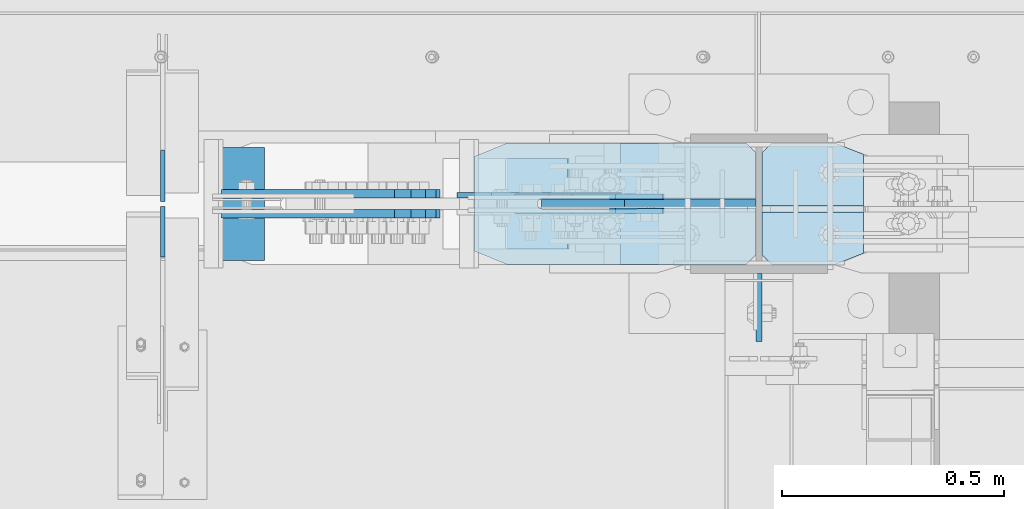
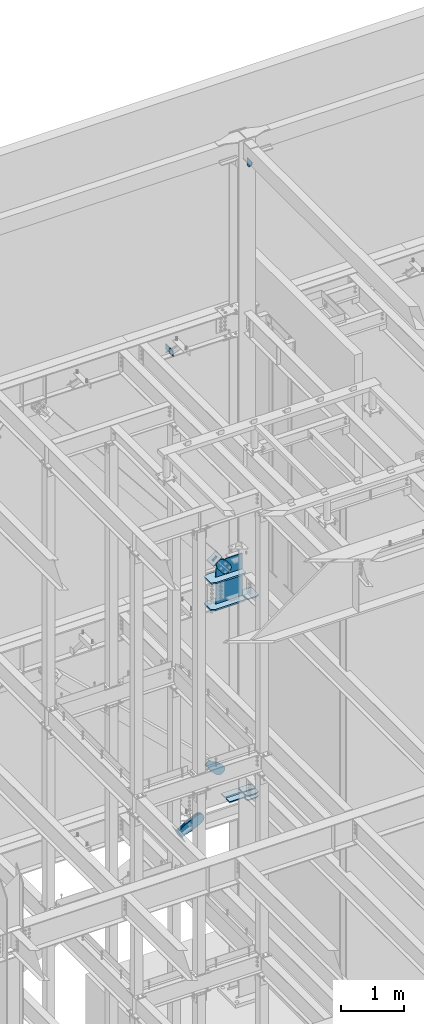
# One storey, part 1104 of 1179: 19 plates, 9 elements without a shape of their own.
"""IFC2X3 building model written with IfcOpenShell, lengths in millimetres."""

from ifc_helpers import new_model, si_unit, frame, origin_with_axes, place, context, subcontext, project, spatial, faceted_brep, material, type_object, element, aggregate, save


model = new_model("IFC2X3")

# Units and contexts
model_context = context("Model", 3, precision=1e-05, world=origin_with_axes())
body_context = subcontext(model_context, "Body", "Model", "MODEL_VIEW")
ifc_project = project(units=[si_unit("LENGTHUNIT", "METRE", prefix="MILLI"), si_unit("AREAUNIT", "SQUARE_METRE"), si_unit("VOLUMEUNIT", "CUBIC_METRE"), si_unit("MASSUNIT", "GRAM", prefix="KILO"), si_unit("TIMEUNIT", "SECOND"), si_unit("PLANEANGLEUNIT", "RADIAN"), si_unit("SOLIDANGLEUNIT", "STERADIAN"), si_unit("THERMODYNAMICTEMPERATUREUNIT", "DEGREE_CELSIUS"), si_unit("LUMINOUSINTENSITYUNIT", "LUMEN")], contexts=[model_context])

# Site, building, storey
site_placement = place(None, origin_with_axes())
site = spatial("IfcSite", under=ifc_project, at=site_placement, CompositionType="ELEMENT")
building_placement = place(site_placement, origin_with_axes())
building = spatial("IfcBuilding", under=site, at=building_placement, Name="Undefined", CompositionType="ELEMENT")
storey_placement = place(building_placement, origin_with_axes())
storey = spatial("IfcBuildingStorey", under=building, at=storey_placement, Name="Undefined", CompositionType="ELEMENT", Elevation=0.0)

# Assembly, plate
assembly_1_placement = place(storey_placement, origin_with_axes())
assembly_1 = element("IfcElementAssembly", 1, at=assembly_1_placement, inside=storey, Name="Plate", AssemblyPlace="NOTDEFINED", PredefinedType="RIGID_FRAME")
ifc_material_1 = material(Name="STEEL/A36")
plate_type_1 = type_object("IfcPlateType", PredefinedType="NOTDEFINED")
plate_1_placement = place(assembly_1_placement, frame((15871.0411167617, 41300.4, 8315.96638331913), z_axis=(0.782937860640373, 0.0, 0.622099916714249), x_axis=(0.0, -1.0, 0.0)))
plate_1 = element("IfcPlate", 2, at=plate_1_placement, type_object=plate_type_1, material=ifc_material_1, Name="Plate", context=body_context, shape_type="Brep", body=[
    faceted_brep([(0.0, -3.17500000000109, 0.0), (0.0, -3.17500000000291, 203.200000000368), (0.0, 3.17499999998836, 203.200000000361), (0.0, 3.17500000000109, 7.27595761418343e-12), (203.199999999997, -3.17500000000291, 203.200000000368), (203.199999999997, 3.17499999998836, 203.200000000361), (203.199999999997, -3.17499999999927, 3.63797880709171e-12), (203.199999999997, 3.17499999999382, -3.63797880709171e-12)], [[[0, 1, 2, 3]], [[1, 4, 5, 2]], [[4, 6, 7, 5]], [[6, 0, 3, 7]], [[5, 7, 3, 2]], [[6, 4, 1, 0]]]),
])
aggregate(assembly_1, [plate_1])

# Assembly, plates
assembly_2_placement = place(storey_placement, origin_with_axes())
assembly_2 = element("IfcElementAssembly", 3, at=assembly_2_placement, inside=storey, Name="COLUMN", AssemblyPlace="NOTDEFINED", PredefinedType="RIGID_FRAME")
ifc_material_2 = material(Name="STEEL/A572-GR.50")
plate_type_2 = type_object("IfcPlateType", PredefinedType="NOTDEFINED")
plate_2_placement = place(assembly_2_placement, frame((15817.5535981227, 41335.1078456819, 7478.71299953461), z_axis=(0.0, -1.0, 0.0), x_axis=(1.0, 0.0, 0.0)))
plate_2 = element("IfcPlate", 4, at=plate_2_placement, type_object=plate_type_2, material=ifc_material_2, Name="PLATE", context=body_context, shape_type="Brep", body=[
    faceted_brep([(0.0, -14.2875000000004, 30.1625003814697), (0.0, -14.2875000000004, 242.453264224023), (0.0, 14.2875000000004, 242.453264224023), (0.0, 14.2875000000004, 30.1625003814697), (74.6125030517578, -14.2875000000004, 272.615764605493), (74.6125030517578, 14.2875000000004, 272.615764605493), (613.071401470328, -14.2875000000004, 272.615764605493), (613.071401470328, 14.2875000000004, 272.615764605493), (635.296401851798, -14.2875000000004, 250.390764224023), (635.296401851798, 14.2875000000004, 250.390764224023), (635.296401851798, -14.2875000000004, 147.202764605485), (635.296401851798, 14.2875000000004, 147.202764605485), (153.997318827118, -14.2875000000004, 147.628018508702), (153.997318827118, 14.2875000000004, 147.628018508702), (149.741734881249, -14.2875000000004, 146.784949914079), (149.741734881249, 14.2875000000004, 146.784949914079), (146.133248221176, -14.2875000000004, 144.376717491818), (146.133248221176, 14.2875000000004, 144.376717491818), (143.721828446049, -14.2875000000004, 140.770360043687), (143.721828446049, 14.2875000000004, 140.770360043687), (142.875000142223, -14.2875000000004, 136.525345872607), (142.875000142223, 14.2875000000004, 136.525345872607), (143.720888851711, -14.2875000000004, 132.272776157457), (143.720888851711, 14.2875000000004, 132.272776157457), (146.129776092153, -14.2875000000004, 128.667621631801), (146.129776092153, 14.2875000000004, 128.667621631801), (149.734930617809, -14.2875000000004, 126.258734391362), (149.734930617809, 14.2875000000004, 126.258734391362), (153.987500332958, -14.2875000000004, 125.412845681873), (153.987500332958, 14.2875000000004, 125.412845681873), (635.296401994021, -14.2875000000004, 125.412845681873), (635.296401994021, 14.2875000000004, 125.412845681873), (635.296401877002, -14.2875000000004, 22.2250003814697), (635.296401877002, 14.2875000000004, 22.2250003814697), (613.071401470328, -14.2875000000004, 0.0), (613.071401470328, 14.2875000000004, 0.0), (74.6125030517578, -14.2875000000004, 0.0), (74.6125030517578, 14.2875000000004, 0.0)], [[[0, 1, 2, 3]], [[1, 4, 5, 2]], [[4, 6, 7, 5]], [[6, 8, 9, 7]], [[8, 10, 11, 9]], [[10, 12, 13, 11]], [[12, 14, 15, 13]], [[14, 16, 17, 15]], [[16, 18, 19, 17]], [[18, 20, 21, 19]], [[20, 22, 23, 21]], [[22, 24, 25, 23]], [[24, 26, 27, 25]], [[26, 28, 29, 27]], [[28, 30, 31, 29]], [[30, 32, 33, 31]], [[32, 34, 35, 33]], [[34, 36, 37, 35]], [[36, 0, 3, 37]], [[5, 7, 9, 11, 13, 15, 17, 19, 21, 23, 25, 27, 29, 31, 33, 35, 37, 3, 2]], [[36, 34, 32, 30, 28, 26, 24, 22, 20, 18, 16, 14, 12, 10, 8, 6, 4, 1, 0]]]),
])
plate_3_placement = place(assembly_2_placement, frame((15817.5535981227, 41335.1078456819, 7999.4125), z_axis=(0.0, -1.0, 0.0), x_axis=(1.0, 0.0, 0.0)))
plate_3 = element("IfcPlate", 5, at=plate_3_placement, type_object=plate_type_2, material=ifc_material_2, Name="PLATE", context=body_context, shape_type="Brep", body=[
    faceted_brep([(0.0, -14.2875000000004, 30.1625003814697), (0.0, -14.2875000000004, 242.453264224023), (0.0, 14.2875000000004, 242.453264224023), (0.0, 14.2875000000004, 30.1625003814697), (74.6125030517578, -14.2875000000004, 272.615764605493), (74.6125030517578, 14.2875000000004, 272.615764605493), (613.071401470328, -14.2875000000004, 272.615764605493), (613.071401470328, 14.2875000000004, 272.615764605493), (635.296401851798, -14.2875000000004, 250.390764224023), (635.296401851798, 14.2875000000004, 250.390764224023), (635.296401851798, -14.2875000000004, 147.202764605485), (635.296401851798, 14.2875000000004, 147.202764605485), (153.997318827118, -14.2875000000004, 147.628018508702), (153.997318827118, 14.2875000000004, 147.628018508702), (149.741734881249, -14.2875000000004, 146.784949914079), (149.741734881249, 14.2875000000004, 146.784949914079), (146.133248221176, -14.2875000000004, 144.376717491818), (146.133248221176, 14.2875000000004, 144.376717491818), (143.721828446049, -14.2875000000004, 140.770360043687), (143.721828446049, 14.2875000000004, 140.770360043687), (142.875000142223, -14.2875000000004, 136.525345872607), (142.875000142223, 14.2875000000004, 136.525345872607), (143.720888851711, -14.2875000000004, 132.272776157457), (143.720888851711, 14.2875000000004, 132.272776157457), (146.129776092153, -14.2875000000004, 128.667621631801), (146.129776092153, 14.2875000000004, 128.667621631801), (149.734930617809, -14.2875000000004, 126.258734391362), (149.734930617809, 14.2875000000004, 126.258734391362), (153.987500332958, -14.2875000000004, 125.412845681873), (153.987500332958, 14.2875000000004, 125.412845681873), (635.296401994021, -14.2875000000004, 125.412845681873), (635.296401994021, 14.2875000000004, 125.412845681873), (635.296401877002, -14.2875000000004, 22.2250003814697), (635.296401877002, 14.2875000000004, 22.2250003814697), (613.071401470328, -14.2875000000004, 0.0), (613.071401470328, 14.2875000000004, 0.0), (74.6125030517578, -14.2875000000004, 0.0), (74.6125030517578, 14.2875000000004, 0.0)], [[[0, 1, 2, 3]], [[1, 4, 5, 2]], [[4, 6, 7, 5]], [[6, 8, 9, 7]], [[8, 10, 11, 9]], [[10, 12, 13, 11]], [[12, 14, 15, 13]], [[14, 16, 17, 15]], [[16, 18, 19, 17]], [[18, 20, 21, 19]], [[20, 22, 23, 21]], [[22, 24, 25, 23]], [[24, 26, 27, 25]], [[26, 28, 29, 27]], [[28, 30, 31, 29]], [[30, 32, 33, 31]], [[32, 34, 35, 33]], [[34, 36, 37, 35]], [[36, 0, 3, 37]], [[5, 7, 9, 11, 13, 15, 17, 19, 21, 23, 25, 27, 29, 31, 33, 35, 37, 3, 2]], [[36, 34, 32, 30, 28, 26, 24, 22, 20, 18, 16, 14, 12, 10, 8, 6, 4, 1, 0]]]),
])
plate_type_3 = type_object("IfcPlateType", PredefinedType="NOTDEFINED")
plate_4_placement = place(assembly_2_placement, frame((16694.15, 41335.325, 3644.9), z_axis=(0.0, -1.0, 0.0), x_axis=(-1.0, 0.0, 0.0)))
plate_4 = element("IfcPlate", 6, at=plate_4_placement, type_object=plate_type_3, material=ifc_material_2, Name="PLATE", context=body_context, shape_type="Brep", body=[
    faceted_brep([(0.0, -9.52499999999964, 25.3999996185303), (0.0, -9.52500000000009, 140.493749921945), (0.0, 9.52500000000009, 140.493749921945), (0.0, 9.52499999999964, 25.3999996185303), (228.600000000002, -9.52500000000009, 140.493749921945), (228.600000000002, 9.52500000000009, 140.493749921945), (228.599999999999, -9.52499999999964, 22.2250003814697), (228.599999999999, 9.52499999999964, 22.2250003814697), (206.374999618529, -9.52499999999964, 0.0), (206.374999618529, 9.52499999999964, 0.0), (63.5, -9.52500000000009, 0.0), (63.5, 9.52500000000009, 0.0)], [[[0, 1, 2, 3]], [[1, 4, 5, 2]], [[4, 6, 7, 5]], [[6, 8, 9, 7]], [[8, 10, 11, 9]], [[10, 0, 3, 11]], [[5, 7, 9, 11, 3, 2]], [[10, 8, 6, 4, 1, 0]]]),
])
plate_type_4 = type_object("IfcPlateType", PredefinedType="NOTDEFINED")
plate_5_placement = place(assembly_2_placement, frame((16694.15, 41062.275, 3644.9), z_axis=(0.0, 1.0, 0.0), x_axis=(-1.0, 0.0, 0.0)))
plate_5 = element("IfcPlate", 7, at=plate_5_placement, type_object=plate_type_4, material=ifc_material_2, Name="PLATE", context=body_context, shape_type="Brep", body=[
    faceted_brep([(0.0, -9.52499999999964, 25.3999996185303), (0.0, -9.52500000000009, 116.681249990812), (0.0, 9.52500000000009, 116.681249990812), (0.0, 9.52499999999964, 25.3999996185303), (228.600000000002, -9.52500000000009, 116.681249990812), (228.600000000002, 9.52500000000009, 116.681249990812), (228.599999999999, -9.52499999999964, 22.2250003814697), (228.599999999999, 9.52499999999964, 22.2250003814697), (206.374999618529, -9.52499999999964, 0.0), (206.374999618529, 9.52499999999964, 0.0), (63.5, -9.52500000000009, 0.0), (63.5, 9.52500000000009, 0.0)], [[[0, 1, 2, 3]], [[1, 4, 5, 2]], [[4, 6, 7, 5]], [[6, 8, 9, 7]], [[8, 10, 11, 9]], [[10, 0, 3, 11]], [[5, 7, 9, 11, 3, 2]], [[10, 8, 6, 4, 1, 0]]]),
])
plate_type_5 = type_object("IfcPlateType", PredefinedType="NOTDEFINED")
plate_6_placement = place(assembly_2_placement, frame((16459.2, 40889.2375061035, 16109.95), z_axis=(0.0, 1.0, 0.0), x_axis=(0.0, 0.0, -1.0)))
plate_6 = element("IfcPlate", 8, at=plate_6_placement, type_object=plate_type_5, material=ifc_material_1, Name="PLATE", context=body_context, shape_type="Brep", body=[
    faceted_brep([(0.0, -6.34999999999854, 0.0), (0.0, -6.34999999999854, 152.400000000001), (0.0, 6.34999999999854, 152.400000000001), (0.0, 6.34999999999854, 0.0), (152.399993896484, -6.34999999999854, 152.399993896484), (152.399993896484, 6.34999999999854, 152.399993896484), (152.399993896484, -6.34999999999854, 88.6901931762695), (152.399993896484, 6.34999999999854, 88.6901931762695), (63.5, -6.34999999999854, 0.0), (63.5, 6.34999999999854, 0.0)], [[[0, 1, 2, 3]], [[1, 4, 5, 2]], [[4, 6, 7, 5]], [[6, 8, 9, 7]], [[8, 0, 3, 9]], [[5, 7, 9, 3, 2]], [[8, 6, 4, 1, 0]]]),
])
plate_type_6 = type_object("IfcPlateType", PredefinedType="NOTDEFINED")
plate_7_placement = place(assembly_2_placement, frame((16694.15, 41062.275, 7475.5375), z_axis=(0.0, 1.0, 0.0), x_axis=(-1.0, 0.0, 0.0)))
plate_7 = element("IfcPlate", 9, at=plate_7_placement, type_object=plate_type_6, material=ifc_material_2, Name="PLATE", context=body_context, shape_type="Brep", body=[
    faceted_brep([(0.0, -11.1125000000002, 25.3999996185303), (0.0, -11.1125000000002, 247.650000381473), (0.0, 11.1125000000002, 247.650000381473), (0.0, 11.1125000000002, 25.3999996185303), (63.5, -11.1125000000002, 273.050000000003), (63.5, 11.1125000000002, 273.050000000003), (206.374999618529, -11.1125000000002, 273.050000000003), (206.374999618529, 11.1125000000002, 273.050000000003), (228.599999999999, -11.1125000000002, 250.824999618533), (228.599999999999, 11.1125000000002, 250.824999618533), (228.599999999999, -11.1125000000002, 22.2250003814697), (228.599999999999, 11.1125000000002, 22.2250003814697), (206.374999618529, -11.1125000000002, 0.0), (206.374999618529, 11.1125000000002, 0.0), (63.5, -11.1125000000002, 0.0), (63.5, 11.1125000000002, 0.0)], [[[0, 1, 2, 3]], [[1, 4, 5, 2]], [[4, 6, 7, 5]], [[6, 8, 9, 7]], [[8, 10, 11, 9]], [[10, 12, 13, 11]], [[12, 14, 15, 13]], [[14, 0, 3, 15]], [[5, 7, 9, 11, 13, 15, 3, 2]], [[14, 12, 10, 8, 6, 4, 1, 0]]]),
])
plate_8_placement = place(assembly_2_placement, frame((16694.15, 41062.275, 3563.9375), z_axis=(0.0, 1.0, 0.0), x_axis=(-1.0, 0.0, 0.0)))
plate_8 = element("IfcPlate", 10, at=plate_8_placement, type_object=plate_type_6, material=ifc_material_2, Name="PLATE", context=body_context, shape_type="Brep", body=[
    faceted_brep([(63.5, -11.1125000000002, 0.0), (0.0, -11.1125000000002, 25.3999996185303), (0.0, 11.1125000000002, 25.3999996185303), (63.5, 11.1125000000002, 0.0), (0.0, -11.1125000000002, 247.650000381473), (63.5, -11.1125000000002, 273.050000000003), (63.5, 11.1125000000002, 273.050000000003), (0.0, 11.1125000000002, 247.650000381473), (206.374999618529, -11.1125000000002, 273.050000000003), (206.374999618529, 11.1125000000002, 273.050000000003), (228.599999999999, -11.1125000000002, 250.824999618533), (228.599999999999, 11.1125000000002, 250.824999618533), (228.599999999999, -11.1125000000002, 22.2250003814697), (228.599999999999, 11.1125000000002, 22.2250003814697), (206.374999618529, -11.1125000000002, 0.0), (206.374999618529, 11.1125000000002, 0.0)], [[[0, 1, 2, 3]], [[4, 5, 6, 7]], [[5, 8, 9, 6]], [[8, 10, 11, 9]], [[10, 12, 13, 11]], [[12, 14, 15, 13]], [[14, 0, 3, 15]], [[6, 9, 11, 13, 15, 3, 2, 7]], [[1, 4, 7, 2]], [[0, 14, 12, 10, 8, 5, 4, 1]]]),
])
plate_type_7 = type_object("IfcPlateType", PredefinedType="NOTDEFINED")
plate_9_placement = place(assembly_2_placement, frame((16148.0508052678, 41062.275, 3644.9), z_axis=(0.0, 1.0, 0.0), x_axis=(1.0, 0.0, 0.0)))
plate_9 = element("IfcPlate", 11, at=plate_9_placement, type_object=plate_type_7, material=ifc_material_2, Name="PLATE", context=body_context, shape_type="Brep", body=[
    faceted_brep([(0.0, -9.52499999999964, 0.0), (0.0, -9.52500000000009, 122.237499999996), (0.0, 9.52500000000009, 122.237499999996), (0.0, 9.52499999999964, 0.0), (304.800000000001, -9.52500000000009, 122.237499999996), (304.800000000001, 9.52500000000009, 122.237499999996), (304.800000000001, -9.52500000000009, 22.2250003814697), (304.800000000001, 9.52500000000009, 22.2250003814697), (282.574999618531, -9.52500000000009, 0.0), (282.574999618531, 9.52500000000009, 0.0)], [[[0, 1, 2, 3]], [[1, 4, 5, 2]], [[4, 6, 7, 5]], [[6, 8, 9, 7]], [[8, 0, 3, 9]], [[5, 7, 9, 3, 2]], [[8, 6, 4, 1, 0]]]),
])
plate_10_placement = place(assembly_2_placement, frame((16148.0508052678, 41335.325, 3644.9), z_axis=(0.0, -1.0, 0.0), x_axis=(1.0, 0.0, 0.0)))
plate_10 = element("IfcPlate", 12, at=plate_10_placement, type_object=plate_type_7, material=ifc_material_2, Name="PLATE", context=body_context, shape_type="Brep", body=[
    faceted_brep([(0.0, -9.52499999999964, 0.0), (0.0, -9.52500000000009, 122.237499999996), (0.0, 9.52500000000009, 122.237499999996), (0.0, 9.52499999999964, 0.0), (304.800000000001, -9.52500000000009, 122.237499999996), (304.800000000001, 9.52500000000009, 122.237499999996), (304.800000000001, -9.52500000000009, 22.2250003814697), (304.800000000001, 9.52500000000009, 22.2250003814697), (282.574999618531, -9.52500000000009, 0.0), (282.574999618531, 9.52500000000009, 0.0)], [[[0, 1, 2, 3]], [[1, 4, 5, 2]], [[4, 6, 7, 5]], [[6, 8, 9, 7]], [[8, 0, 3, 9]], [[5, 7, 9, 3, 2]], [[8, 6, 4, 1, 0]]]),
])
plate_type_8 = type_object("IfcPlateType", PredefinedType="NOTDEFINED")
plate_11_placement = place(assembly_2_placement, frame((16452.8499999997, 41198.8, 7445.375), z_axis=(0.0, 0.0, 1.0), x_axis=(-1.0, 0.0, 0.0)))
plate_11 = element("IfcPlate", 13, at=plate_11_placement, type_object=plate_type_8, material=ifc_material_2, Name="PLATE", context=body_context, shape_type="Brep", body=[
    faceted_brep([(0.0, -9.52499999999964, 0.0), (0.0, -9.52500000000146, 866.173326861562), (0.0, 9.52500000000146, 866.173326861562), (0.0, 9.52499999999964, 0.0), (296.459325144328, -9.52500000000146, 866.173326861562), (296.459325144328, 9.52500000000146, 866.173326861562), (482.896403209315, -9.52500000000146, 718.035784193981), (482.896403209315, 9.52500000000146, 718.035784193981), (482.896403209315, -9.52500000000146, 0.0), (482.896403209315, 9.52500000000146, 0.0)], [[[0, 1, 2, 3]], [[1, 4, 5, 2]], [[4, 6, 7, 5]], [[6, 8, 9, 7]], [[8, 0, 3, 9]], [[5, 7, 9, 3, 2]], [[8, 6, 4, 1, 0]]]),
])
aggregate(assembly_2, [plate_2, plate_3, plate_6, plate_7, plate_9, plate_10, plate_5, plate_4, plate_8, plate_11])

# Assembly, plate
assembly_3_placement = place(storey_placement, origin_with_axes())
assembly_3 = element("IfcElementAssembly", 14, at=assembly_3_placement, inside=storey, AssemblyPlace="NOTDEFINED", PredefinedType="RIGID_FRAME")
plate_type_9 = type_object("IfcPlateType", PredefinedType="NOTDEFINED")
plate_12_placement = place(assembly_3_placement, frame((15986.6450585112, 41214.675, 8411.87719094617), z_axis=(-0.782937860640373, 0.0, -0.622099916714249), x_axis=(0.622099916714252, 0.0, -0.782937860640371)))
plate_12 = element("IfcPlate", 15, at=plate_12_placement, type_object=plate_type_9, material=ifc_material_1, context=body_context, shape_type="Brep", body=[
    faceted_brep([(0.0, -6.34999999999854, 0.0), (4.938556230627e-10, -6.34999999999854, 97.1536165479993), (4.938556230627e-10, 6.34999999999854, 97.1536165479993), (0.0, 6.34999999999854, 0.0), (82.5500000003167, -6.34999999999854, 97.1536165479301), (82.5500000003167, 6.34999999999854, 97.1536165479301), (184.150000000318, -6.34999999999854, 142.239308273958), (184.150000000318, 6.34999999999854, 142.239308273958), (327.919242322826, -6.34999999999854, 142.239308273831), (327.919242322826, 6.34999999999854, 142.239308273831), (363.762328722879, -6.34999999999854, 135.109675103751), (363.762328722879, 6.34999999999854, 135.109675103751), (394.148630136872, -6.34999999999854, 114.806197613441), (394.148630136872, 6.34999999999854, 114.806197613441), (414.452107627006, -6.34999999999854, 84.4198961993279), (414.452107627006, 6.34999999999854, 84.4198961993279), (421.581740796876, -6.34999999999854, 48.5768067472527), (421.581740796876, 6.34999999999854, 48.5768067472527), (414.452107626721, -6.34999999999854, 12.7337203474126), (414.452107626721, 6.34999999999854, 12.7337203474126), (394.148630136483, -6.34999999999854, -17.6525810663916), (394.148630136483, 6.34999999999854, -17.6525810663916), (363.762328722555, -6.34999999999854, -37.9560585564504), (363.762328722555, 6.34999999999854, -37.9560585564504), (327.9192407966, -6.34999999999854, -45.0856917263918), (327.9192407966, 6.34999999999854, -45.0856917263918), (184.149999999361, -6.34999999999854, -45.0856917262681), (184.149999999361, 6.34999999999854, -45.0856917262681), (82.550000000203, -6.34999999999854, 1.2732925824821e-10), (82.550000000203, 6.34999999999854, 1.2732925824821e-10)], [[[0, 1, 2, 3]], [[1, 4, 5, 2]], [[4, 6, 7, 5]], [[6, 8, 9, 7]], [[8, 10, 11, 9]], [[10, 12, 13, 11]], [[12, 14, 15, 13]], [[14, 16, 17, 15]], [[16, 18, 19, 17]], [[18, 20, 21, 19]], [[20, 22, 23, 21]], [[22, 24, 25, 23]], [[24, 26, 27, 25]], [[26, 28, 29, 27]], [[28, 0, 3, 29]], [[5, 7, 9, 11, 13, 15, 17, 19, 21, 23, 25, 27, 29, 3, 2]], [[28, 26, 24, 22, 20, 18, 16, 14, 12, 10, 8, 6, 4, 1, 0]]]),
])
aggregate(assembly_3, [plate_12])

assembly_4_placement = place(storey_placement, origin_with_axes())
assembly_4 = element("IfcElementAssembly", 16, at=assembly_4_placement, inside=storey, AssemblyPlace="NOTDEFINED", PredefinedType="RIGID_FRAME")
plate_13_placement = place(assembly_4_placement, frame((15986.6450585112, 41182.925, 8411.87719094617), z_axis=(-0.782937860640373, 0.0, -0.622099916714249), x_axis=(0.622099916714252, 0.0, -0.782937860640371)))
plate_13 = element("IfcPlate", 17, at=plate_13_placement, type_object=plate_type_9, material=ifc_material_1, context=body_context, shape_type="Brep", body=[
    faceted_brep([(0.0, -6.34999999999854, 0.0), (4.938556230627e-10, -6.34999999999854, 97.1536165479993), (4.938556230627e-10, 6.34999999999854, 97.1536165479993), (0.0, 6.34999999999854, 0.0), (82.5500000003167, -6.34999999999854, 97.1536165479301), (82.5500000003167, 6.34999999999854, 97.1536165479301), (184.150000000318, -6.34999999999854, 142.239308273958), (184.150000000318, 6.34999999999854, 142.239308273958), (327.919242322826, -6.34999999999854, 142.239308273831), (327.919242322826, 6.34999999999854, 142.239308273831), (363.762328722879, -6.34999999999854, 135.109675103751), (363.762328722879, 6.34999999999854, 135.109675103751), (394.148630136872, -6.34999999999854, 114.806197613441), (394.148630136872, 6.34999999999854, 114.806197613441), (414.452107627006, -6.34999999999854, 84.4198961993279), (414.452107627006, 6.34999999999854, 84.4198961993279), (421.581740796876, -6.34999999999854, 48.5768067472527), (421.581740796876, 6.34999999999854, 48.5768067472527), (414.452107626721, -6.34999999999854, 12.7337203474126), (414.452107626721, 6.34999999999854, 12.7337203474126), (394.148630136483, -6.34999999999854, -17.6525810663916), (394.148630136483, 6.34999999999854, -17.6525810663916), (363.762328722555, -6.34999999999854, -37.9560585564504), (363.762328722555, 6.34999999999854, -37.9560585564504), (327.9192407966, -6.34999999999854, -45.0856917263918), (327.9192407966, 6.34999999999854, -45.0856917263918), (184.149999999361, -6.34999999999854, -45.0856917262681), (184.149999999361, 6.34999999999854, -45.0856917262681), (82.550000000203, -6.34999999999854, 1.2732925824821e-10), (82.550000000203, 6.34999999999854, 1.2732925824821e-10)], [[[0, 1, 2, 3]], [[1, 4, 5, 2]], [[4, 6, 7, 5]], [[6, 8, 9, 7]], [[8, 10, 11, 9]], [[10, 12, 13, 11]], [[12, 14, 15, 13]], [[14, 16, 17, 15]], [[16, 18, 19, 17]], [[18, 20, 21, 19]], [[20, 22, 23, 21]], [[22, 24, 25, 23]], [[24, 26, 27, 25]], [[26, 28, 29, 27]], [[28, 0, 3, 29]], [[5, 7, 9, 11, 13, 15, 17, 19, 21, 23, 25, 27, 29, 3, 2]], [[28, 26, 24, 22, 20, 18, 16, 14, 12, 10, 8, 6, 4, 1, 0]]]),
])
aggregate(assembly_4, [plate_13])

assembly_5_placement = place(storey_placement, origin_with_axes())
assembly_5 = element("IfcElementAssembly", 18, at=assembly_5_placement, inside=storey, AssemblyPlace="NOTDEFINED", PredefinedType="RIGID_FRAME")
plate_14_placement = place(assembly_5_placement, frame((15857.7070541073, 41217.85, 4480.42496888089), z_axis=(-0.691222646058184, 0.0, -0.722641857060828), x_axis=(0.722641857060828, 0.0, -0.691222646058184)))
plate_14 = element("IfcPlate", 19, at=plate_14_placement, type_object=plate_type_9, material=ifc_material_1, context=body_context, shape_type="Brep", body=[
    faceted_brep([(0.0, -6.34999999999854, 0.0), (-4.35647962149233e-10, -6.34999999999854, 112.184930806416), (-4.35647962149233e-10, 6.34999999999854, 112.184930806416), (0.0, 6.34999999999854, 0.0), (82.5499999996491, -6.34999999999854, 112.184930806461), (82.5499999996491, 6.34999999999854, 112.184930806461), (184.149999999618, -6.34999999999854, 149.75496540347), (184.149999999618, 6.34999999999854, 149.75496540347), (327.919242323534, -6.34999999999854, 149.754965403559), (327.919242323534, 6.34999999999854, 149.754965403559), (363.762328723451, -6.34999999999854, 142.625332233587), (363.762328723451, 6.34999999999854, 142.625332233587), (394.148630137406, -6.34999999999854, 122.321854743475), (394.148630137406, 6.34999999999854, 122.321854743475), (414.452107627645, -6.34999999999854, 91.9355533295929), (414.452107627645, 6.34999999999854, 91.9355533295929), (421.581740797776, -6.34999999999854, 56.0924638777396), (421.581740797776, 6.34999999999854, 56.0924638777396), (414.452107627878, -6.34999999999854, 20.2493774776722), (414.452107627878, 6.34999999999854, 20.2493774776722), (394.14863013775, -6.34999999999854, -10.1369239363994), (394.14863013775, 6.34999999999854, -10.1369239363994), (363.762328723789, -6.34999999999854, -30.4404014266784), (363.762328723789, 6.34999999999854, -30.4404014266784), (327.919240798041, -6.34999999999854, -37.570034596738), (327.919240798041, 6.34999999999854, -37.570034596738), (184.150000000338, -6.34999999999854, -37.5700345968289), (184.150000000338, 6.34999999999854, -37.5700345968289), (82.550000000203, -6.34999999999854, 1.2732925824821e-10), (82.550000000203, 6.34999999999854, 1.2732925824821e-10)], [[[0, 1, 2, 3]], [[1, 4, 5, 2]], [[4, 6, 7, 5]], [[6, 8, 9, 7]], [[8, 10, 11, 9]], [[10, 12, 13, 11]], [[12, 14, 15, 13]], [[14, 16, 17, 15]], [[16, 18, 19, 17]], [[18, 20, 21, 19]], [[20, 22, 23, 21]], [[22, 24, 25, 23]], [[24, 26, 27, 25]], [[26, 28, 29, 27]], [[28, 0, 3, 29]], [[5, 7, 9, 11, 13, 15, 17, 19, 21, 23, 25, 27, 29, 3, 2]], [[28, 26, 24, 22, 20, 18, 16, 14, 12, 10, 8, 6, 4, 1, 0]]]),
])
aggregate(assembly_5, [plate_14])

assembly_6_placement = place(storey_placement, origin_with_axes())
assembly_6 = element("IfcElementAssembly", 20, at=assembly_6_placement, inside=storey, AssemblyPlace="NOTDEFINED", PredefinedType="RIGID_FRAME")
plate_type_10 = type_object("IfcPlateType", PredefinedType="NOTDEFINED")
plate_15_placement = place(assembly_6_placement, frame((15319.4582632568, 41221.025, 3175.66051074014), z_axis=(-0.443172292794208, 0.0, 0.896436455583732), x_axis=(0.896436455583732, 0.0, 0.443172292794209)))
plate_15 = element("IfcPlate", 21, at=plate_15_placement, type_object=plate_type_10, material=ifc_material_1, context=body_context, shape_type="Brep", body=[
    faceted_brep([(0.0, -9.52499999999964, 0.0), (2.34649633057415e-10, -9.52500000000146, 158.394212975713), (2.34649633057415e-10, 9.52500000000146, 158.394212975713), (0.0, 9.52499999999964, 0.0), (82.5499999999411, -9.52500000000146, 158.394212975733), (82.5499999999411, 9.52500000000146, 158.394212975733), (184.149999999603, -9.52500000000146, 176.034606487957), (184.149999999603, 9.52500000000146, 176.034606487957), (402.829297669137, -9.52500000000146, 176.034606488008), (402.829297669137, 9.52500000000146, 176.034606488008), (439.887405134748, -9.52500000000146, 168.663290601407), (439.887405134748, 9.52500000000146, 168.663290601407), (471.303751671294, -9.52500000000146, 147.671558964187), (471.303751671294, 9.52500000000146, 147.671558964187), (492.295483308464, -9.52500000000146, 116.255212427598), (492.295483308464, 9.52500000000146, 116.255212427598), (499.666799195016, -9.52500000000146, 79.1971080136309), (499.666799195016, 9.52500000000146, 79.1971080136309), (492.295483308397, -9.52500000000146, 42.1390005480966), (492.295483308397, 9.52500000000146, 42.1390005480966), (471.30375167123, -9.52500000000146, 10.7226540116199), (471.30375167123, 9.52500000000146, 10.7226540116199), (439.887405134747, -9.52500000000146, -10.2690776255231), (439.887405134747, 9.52500000000146, -10.2690776255231), (402.829299195224, -9.52500000000146, -17.6403935121043), (402.829299195224, 9.52500000000146, -17.6403935121043), (184.149999999325, -9.52500000000146, -17.6403935121562), (184.149999999325, 9.52500000000146, -17.6403935121562), (82.5499999997119, -9.52500000000146, 1.81898940354586e-11), (82.5499999997119, 9.52500000000146, 1.81898940354586e-11)], [[[0, 1, 2, 3]], [[1, 4, 5, 2]], [[4, 6, 7, 5]], [[6, 8, 9, 7]], [[8, 10, 11, 9]], [[10, 12, 13, 11]], [[12, 14, 15, 13]], [[14, 16, 17, 15]], [[16, 18, 19, 17]], [[18, 20, 21, 19]], [[20, 22, 23, 21]], [[22, 24, 25, 23]], [[24, 26, 27, 25]], [[26, 28, 29, 27]], [[28, 0, 3, 29]], [[5, 7, 9, 11, 13, 15, 17, 19, 21, 23, 25, 27, 29, 3, 2]], [[28, 26, 24, 22, 20, 18, 16, 14, 12, 10, 8, 6, 4, 1, 0]]]),
])
aggregate(assembly_6, [plate_15])

assembly_7_placement = place(storey_placement, origin_with_axes())
assembly_7 = element("IfcElementAssembly", 22, at=assembly_7_placement, inside=storey, AssemblyPlace="NOTDEFINED", PredefinedType="RIGID_FRAME")
plate_16_placement = place(assembly_7_placement, frame((15319.4582632568, 41176.575, 3175.66051074014), z_axis=(-0.443172292794208, 0.0, 0.896436455583732), x_axis=(0.896436455583732, 0.0, 0.443172292794209)))
plate_16 = element("IfcPlate", 23, at=plate_16_placement, type_object=plate_type_10, material=ifc_material_1, context=body_context, shape_type="Brep", body=[
    faceted_brep([(0.0, -9.52499999999964, 0.0), (2.34649633057415e-10, -9.52500000000146, 158.394212975713), (2.34649633057415e-10, 9.52500000000146, 158.394212975713), (0.0, 9.52499999999964, 0.0), (82.5499999999411, -9.52500000000146, 158.394212975733), (82.5499999999411, 9.52500000000146, 158.394212975733), (184.149999999603, -9.52500000000146, 176.034606487957), (184.149999999603, 9.52500000000146, 176.034606487957), (402.829297669137, -9.52500000000146, 176.034606488008), (402.829297669137, 9.52500000000146, 176.034606488008), (439.887405134748, -9.52500000000146, 168.663290601407), (439.887405134748, 9.52500000000146, 168.663290601407), (471.303751671294, -9.52500000000146, 147.671558964187), (471.303751671294, 9.52500000000146, 147.671558964187), (492.295483308464, -9.52500000000146, 116.255212427598), (492.295483308464, 9.52500000000146, 116.255212427598), (499.666799195016, -9.52500000000146, 79.1971080136309), (499.666799195016, 9.52500000000146, 79.1971080136309), (492.295483308397, -9.52500000000146, 42.1390005480966), (492.295483308397, 9.52500000000146, 42.1390005480966), (471.30375167123, -9.52500000000146, 10.7226540116199), (471.30375167123, 9.52500000000146, 10.7226540116199), (439.887405134747, -9.52500000000146, -10.2690776255231), (439.887405134747, 9.52500000000146, -10.2690776255231), (402.829299195224, -9.52500000000146, -17.6403935121043), (402.829299195224, 9.52500000000146, -17.6403935121043), (184.149999999325, -9.52500000000146, -17.6403935121562), (184.149999999325, 9.52500000000146, -17.6403935121562), (82.5499999997119, -9.52500000000146, 1.81898940354586e-11), (82.5499999997119, 9.52500000000146, 1.81898940354586e-11)], [[[0, 1, 2, 3]], [[1, 4, 5, 2]], [[4, 6, 7, 5]], [[6, 8, 9, 7]], [[8, 10, 11, 9]], [[10, 12, 13, 11]], [[12, 14, 15, 13]], [[14, 16, 17, 15]], [[16, 18, 19, 17]], [[18, 20, 21, 19]], [[20, 22, 23, 21]], [[22, 24, 25, 23]], [[24, 26, 27, 25]], [[26, 28, 29, 27]], [[28, 0, 3, 29]], [[5, 7, 9, 11, 13, 15, 17, 19, 21, 23, 25, 27, 29, 3, 2]], [[28, 26, 24, 22, 20, 18, 16, 14, 12, 10, 8, 6, 4, 1, 0]]]),
])
aggregate(assembly_7, [plate_16])

assembly_8_placement = place(storey_placement, origin_with_axes())
assembly_8 = element("IfcElementAssembly", 24, at=assembly_8_placement, inside=storey, Name="Plate", AssemblyPlace="NOTDEFINED", PredefinedType="RIGID_FRAME")
plate_type_11 = type_object("IfcPlateType", PredefinedType="NOTDEFINED")
plate_17_placement = place(assembly_8_placement, frame((15343.4893669279, 41071.8, 3134.21532634697), z_axis=(-0.443172292794208, 0.0, 0.896436455583732), x_axis=(0.0, 1.0, 0.0)))
plate_17 = element("IfcPlate", 25, at=plate_17_placement, type_object=plate_type_11, material=ifc_material_1, Name="Plate", context=body_context, shape_type="Brep", body=[
    faceted_brep([(0.0, -3.17500000000109, 0.0), (0.0, -3.17499999986103, 253.99999999967), (0.0, 3.17500000013752, 253.999999999668), (0.0, 3.17500000000109, 7.27595761418343e-12), (254.0, -3.17499999986103, 253.99999999967), (254.0, 3.17500000013752, 253.999999999668), (254.0, -3.17500000000109, 9.09494701772928e-13), (254.0, 3.17499999999745, -1.36424205265939e-12)], [[[0, 1, 2, 3]], [[1, 4, 5, 2]], [[4, 6, 7, 5]], [[6, 0, 3, 7]], [[5, 7, 3, 2]], [[6, 4, 1, 0]]]),
])
aggregate(assembly_8, [plate_17])

# Assembly, plates
assembly_9_placement = place(storey_placement, origin_with_axes())
assembly_9 = element("IfcElementAssembly", 26, at=assembly_9_placement, inside=storey, Name="BEAM", AssemblyPlace="NOTDEFINED", PredefinedType="RIGID_FRAME")
plate_type_12 = type_object("IfcPlateType", PredefinedType="NOTDEFINED")
plate_18_placement = place(assembly_9_placement, frame((15117.7625, 41193.24375, 12690.4749987075), z_axis=(0.0, -0.707106781186506, 0.707106781186589), x_axis=(0.0, -0.70710678118659, -0.707106781186505)))
plate_18 = element("IfcPlate", 27, at=plate_18_placement, type_object=plate_type_12, material=ifc_material_1, Name="PLATE", context=body_context, shape_type="Brep", body=[
    faceted_brep([(0.0, -4.76249999999709, 0.0), (-67.3519210815575, -4.76250000000073, 67.3519210815502), (-67.3519210815575, 4.76250000000073, 67.3519210815502), (0.0, 4.76249999999709, 0.0), (13.4703845975746, -4.76250000000073, 148.174224853334), (13.4703845975746, 4.76250000000073, 148.174224853334), (94.2926864622132, -4.76250000000073, 67.3519210813465), (94.2926864622132, 4.76250000000073, 67.3519210813465), (26.9407683631525, -4.76249999999709, -6.18456397205591e-11), (26.9407683631525, 4.76249999999709, -6.18456397205591e-11)], [[[0, 1, 2, 3]], [[1, 4, 5, 2]], [[4, 6, 7, 5]], [[6, 8, 9, 7]], [[8, 0, 3, 9]], [[5, 7, 9, 3, 2]], [[8, 6, 4, 1, 0]]]),
])
plate_19_placement = place(assembly_9_placement, frame((15117.7625, 41204.35625, 12690.4749987075), z_axis=(0.0, 0.707106781186542, 0.707106781186553), x_axis=(0.0, 0.707106781186553, -0.707106781186542)))
plate_19 = element("IfcPlate", 28, at=plate_19_placement, type_object=plate_type_12, material=ifc_material_1, Name="PLATE", context=body_context, shape_type="Brep", body=[
    faceted_brep([(0.0, -4.76249999999709, 0.0), (-67.3519210815575, -4.76250000000073, 67.3519210815502), (-67.3519210815575, 4.76250000000073, 67.3519210815502), (0.0, 4.76249999999709, 0.0), (13.4703845975746, -4.76250000000073, 148.174224853334), (13.4703845975746, 4.76250000000073, 148.174224853334), (94.2926864622132, -4.76250000000073, 67.3519210813465), (94.2926864622132, 4.76250000000073, 67.3519210813465), (26.9407683631525, -4.76249999999709, -6.18456397205591e-11), (26.9407683631525, 4.76249999999709, -6.18456397205591e-11)], [[[0, 1, 2, 3]], [[1, 4, 5, 2]], [[4, 6, 7, 5]], [[6, 8, 9, 7]], [[8, 0, 3, 9]], [[5, 7, 9, 3, 2]], [[8, 6, 4, 1, 0]]]),
])
aggregate(assembly_9, [plate_18, plate_19])

save(model, "model.ifc")
